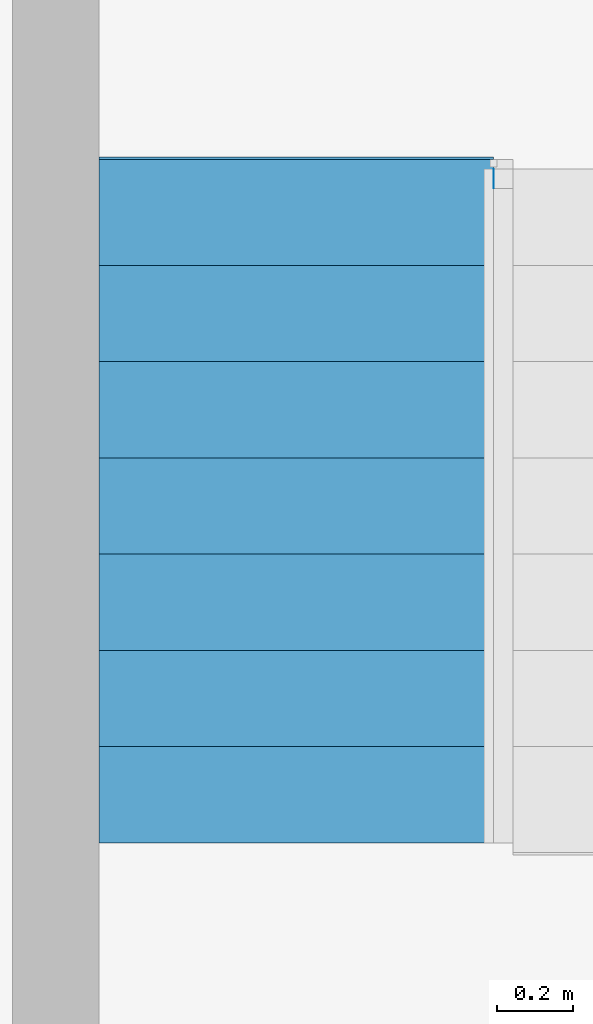
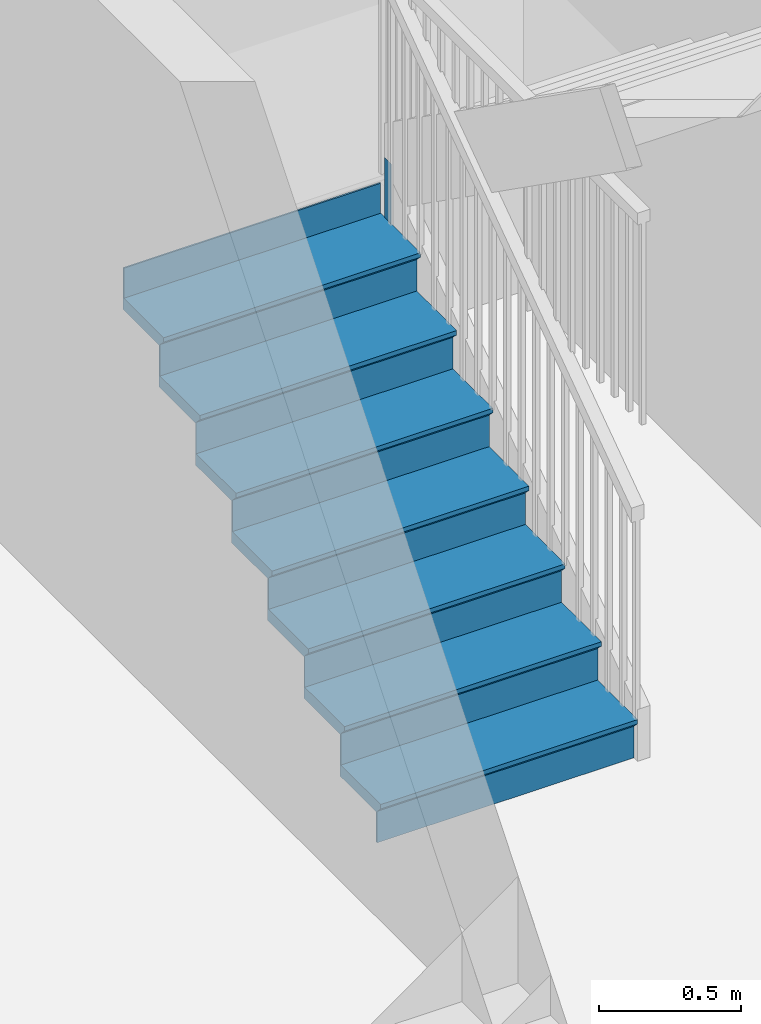
# One storey, part 4 of 6: 1 member, 1 stair flight, 1 element without a shape of its own.
"""IFC2X3 building model written with IfcOpenShell, lengths in feet."""

from ifc_helpers import new_model, entity, si_unit, converted_unit, derived_unit, direction, frame, origin, place, context, subcontext, project, spatial, face_set, faceted_brep, surface_model, material, type_object, element, aggregate, save


model = new_model("IFC2X3")

# Units and contexts
model_context = context("Model", 3, precision=0.0001, world=origin(), true_north=direction((6.123031769111886e-17, 1.0)))
body_context = subcontext(model_context, "Body", "Model", "MODEL_VIEW")
ifc_project = project(units=[converted_unit("LENGTHUNIT", "FOOT", entity("IfcLengthMeasure", 0.3048), si_unit("LENGTHUNIT", "METRE"), dimensions=[1, 0, 0, 0, 0, 0, 0]), converted_unit("AREAUNIT", "SQUARE FOOT", entity("IfcAreaMeasure", 0.09290304), si_unit("AREAUNIT", "SQUARE_METRE"), dimensions=[2, 0, 0, 0, 0, 0, 0]), converted_unit("VOLUMEUNIT", "CUBIC FOOT", entity("IfcVolumeMeasure", 0.028316846592000004), si_unit("VOLUMEUNIT", "CUBIC_METRE"), dimensions=[3, 0, 0, 0, 0, 0, 0]), converted_unit("PLANEANGLEUNIT", "DEGREE", entity("IfcPlaneAngleMeasure", 0.017453292519943278), si_unit("PLANEANGLEUNIT", "RADIAN"), dimensions=[0, 0, 0, 0, 0, 0, 0]), si_unit("MASSUNIT", "GRAM", prefix="KILO"), derived_unit("MASSDENSITYUNIT", [(si_unit("MASSUNIT", "GRAM", prefix="KILO"), 1), (si_unit("LENGTHUNIT", "METRE"), -3)]), derived_unit("IONCONCENTRATIONUNIT", [(si_unit("MASSUNIT", "GRAM", prefix="KILO"), 1), (si_unit("LENGTHUNIT", "METRE"), -3)]), derived_unit("MOMENTOFINERTIAUNIT", [(si_unit("LENGTHUNIT", "METRE"), 4)]), si_unit("TIMEUNIT", "SECOND"), si_unit("FREQUENCYUNIT", "HERTZ"), si_unit("THERMODYNAMICTEMPERATUREUNIT", "DEGREE_CELSIUS"), derived_unit("THERMALTRANSMITTANCEUNIT", [(si_unit("MASSUNIT", "GRAM", prefix="KILO"), 1), (si_unit("THERMODYNAMICTEMPERATUREUNIT", "KELVIN"), -1), (si_unit("TIMEUNIT", "SECOND"), -3)]), derived_unit("THERMALCONDUCTANCEUNIT", [(si_unit("MASSUNIT", "GRAM", prefix="KILO"), 1), (si_unit("THERMODYNAMICTEMPERATUREUNIT", "KELVIN"), -1), (si_unit("TIMEUNIT", "SECOND"), -3), (si_unit("LENGTHUNIT", "METRE"), 1)]), derived_unit("VOLUMETRICFLOWRATEUNIT", [(si_unit("LENGTHUNIT", "METRE"), 3), (si_unit("TIMEUNIT", "SECOND"), -1)]), derived_unit("MASSFLOWRATEUNIT", [(si_unit("MASSUNIT", "GRAM", prefix="KILO"), 1), (si_unit("TIMEUNIT", "SECOND"), -1)]), derived_unit("ROTATIONALFREQUENCYUNIT", [(si_unit("TIMEUNIT", "SECOND"), -1)]), si_unit("ELECTRICCURRENTUNIT", "AMPERE"), si_unit("ELECTRICVOLTAGEUNIT", "VOLT"), si_unit("POWERUNIT", "WATT"), converted_unit("FORCEUNIT", "KIP", entity("IfcForceMeasure", 2.088543423315013e-05), si_unit("FORCEUNIT", "NEWTON"), dimensions=[1, 1, -2, 0, 0, 0, 0]), si_unit("ILLUMINANCEUNIT", "LUX"), si_unit("LUMINOUSFLUXUNIT", "LUMEN"), si_unit("LUMINOUSINTENSITYUNIT", "CANDELA"), si_unit("ENERGYUNIT", "JOULE"), derived_unit("USERDEFINED", [(si_unit("MASSUNIT", "GRAM", prefix="KILO"), -1), (si_unit("LENGTHUNIT", "METRE"), -2), (si_unit("TIMEUNIT", "SECOND"), 3), (si_unit("LUMINOUSFLUXUNIT", "LUMEN"), 1)]), derived_unit("USERDEFINED", [(si_unit("MASSUNIT", "GRAM", prefix="KILO"), 1), (si_unit("TIMEUNIT", "SECOND"), -3), (si_unit("LENGTHUNIT", "METRE"), 3), (si_unit("ELECTRICCURRENTUNIT", "AMPERE"), -2)]), derived_unit("SOUNDPOWERUNIT", [(si_unit("MASSUNIT", "GRAM", prefix="KILO"), 1), (si_unit("TIMEUNIT", "SECOND"), -3), (si_unit("LENGTHUNIT", "METRE"), 2)]), derived_unit("SOUNDPRESSUREUNIT", [(si_unit("MASSUNIT", "GRAM", prefix="KILO"), 1), (si_unit("LENGTHUNIT", "METRE"), -1), (si_unit("TIMEUNIT", "SECOND"), -2)]), derived_unit("LINEARVELOCITYUNIT", [(si_unit("LENGTHUNIT", "METRE"), 1), (si_unit("TIMEUNIT", "SECOND"), -1)]), si_unit("PRESSUREUNIT", "PASCAL"), derived_unit("USERDEFINED", [(si_unit("MASSUNIT", "GRAM", prefix="KILO"), 1), (si_unit("LENGTHUNIT", "METRE"), -2), (si_unit("TIMEUNIT", "SECOND"), -2)]), derived_unit("LINEARFORCEUNIT", [(si_unit("MASSUNIT", "GRAM", prefix="KILO"), 1), (si_unit("TIMEUNIT", "SECOND"), -2)]), derived_unit("PLANARFORCEUNIT", [(si_unit("MASSUNIT", "GRAM", prefix="KILO"), 1), (si_unit("LENGTHUNIT", "METRE"), -1), (si_unit("TIMEUNIT", "SECOND"), -2)]), derived_unit("SPECIFICHEATCAPACITYUNIT", [(si_unit("THERMODYNAMICTEMPERATUREUNIT", "KELVIN"), -1), (si_unit("LENGTHUNIT", "METRE"), 2), (si_unit("TIMEUNIT", "SECOND"), -2)]), derived_unit("HEATFLUXDENSITYUNIT", [(si_unit("MASSUNIT", "GRAM", prefix="KILO"), 1), (si_unit("TIMEUNIT", "SECOND"), -3)]), derived_unit("HEATINGVALUEUNIT", [(si_unit("LENGTHUNIT", "METRE"), 2), (si_unit("TIMEUNIT", "SECOND"), -2)]), derived_unit("VAPORPERMEABILITYUNIT", [(si_unit("LENGTHUNIT", "METRE"), -1), (si_unit("TIMEUNIT", "SECOND"), 1)]), derived_unit("DYNAMICVISCOSITYUNIT", [(si_unit("MASSUNIT", "GRAM", prefix="KILO"), 1), (si_unit("TIMEUNIT", "SECOND"), -1), (si_unit("LENGTHUNIT", "METRE"), -1)]), derived_unit("THERMALEXPANSIONCOEFFICIENTUNIT", [(si_unit("THERMODYNAMICTEMPERATUREUNIT", "KELVIN"), -1)]), derived_unit("MODULUSOFELASTICITYUNIT", [(si_unit("MASSUNIT", "GRAM", prefix="KILO"), 1), (si_unit("LENGTHUNIT", "METRE"), -1), (si_unit("TIMEUNIT", "SECOND"), -2)]), derived_unit("ISOTHERMALMOISTURECAPACITYUNIT", [(si_unit("LENGTHUNIT", "METRE"), 3), (si_unit("MASSUNIT", "GRAM", prefix="KILO"), -1)]), derived_unit("MOISTUREDIFFUSIVITYUNIT", [(si_unit("TIMEUNIT", "SECOND"), -1), (si_unit("LENGTHUNIT", "METRE"), 2)]), derived_unit("MASSPERLENGTHUNIT", [(si_unit("MASSUNIT", "GRAM", prefix="KILO"), 1), (si_unit("LENGTHUNIT", "METRE"), -1)]), derived_unit("THERMALRESISTANCEUNIT", [(si_unit("MASSUNIT", "GRAM", prefix="KILO"), -1), (si_unit("TIMEUNIT", "SECOND"), 3), (si_unit("THERMODYNAMICTEMPERATUREUNIT", "KELVIN"), 1)]), derived_unit("ACCELERATIONUNIT", [(si_unit("LENGTHUNIT", "METRE"), 1), (si_unit("TIMEUNIT", "SECOND"), -2)]), derived_unit("ANGULARVELOCITYUNIT", [(si_unit("TIMEUNIT", "SECOND"), -1), (si_unit("PLANEANGLEUNIT", "RADIAN"), 1)]), derived_unit("LINEARSTIFFNESSUNIT", [(si_unit("MASSUNIT", "GRAM", prefix="KILO"), 1), (si_unit("TIMEUNIT", "SECOND"), -2)]), derived_unit("WARPINGCONSTANTUNIT", [(si_unit("LENGTHUNIT", "METRE"), 6)]), derived_unit("LINEARMOMENTUNIT", [(si_unit("MASSUNIT", "GRAM", prefix="KILO"), 1), (si_unit("LENGTHUNIT", "METRE"), 1), (si_unit("TIMEUNIT", "SECOND"), -2)]), derived_unit("TORQUEUNIT", [(si_unit("MASSUNIT", "GRAM", prefix="KILO"), 1), (si_unit("LENGTHUNIT", "METRE"), 2), (si_unit("TIMEUNIT", "SECOND"), -2)])], contexts=[model_context])

# Site, building, storey
site_placement = place(None, origin())
site = spatial("IfcSite", under=ifc_project, at=site_placement, CompositionType="ELEMENT")
building_placement = place(site_placement, origin())
building = spatial("IfcBuilding", under=site, at=building_placement, CompositionType="ELEMENT")
storey_placement = place(building_placement, origin())
storey = spatial("IfcBuildingStorey", under=building, at=storey_placement, Name="Level 1", CompositionType="ELEMENT", Elevation=0.0)

# Stair, member, stair flight
type_product = type_object("IfcTypeProduct")
stair_placement = place(storey_placement, origin())
stair = element("IfcStair", 1, at=stair_placement, inside=storey, type_object=type_product, Name="Assembled Stair:Stair", ShapeType="HALF_TURN_STAIR")
ifc_material = material()
member_type = type_object("IfcMemberType", PredefinedType="STRINGER")
member_placement = place(stair_placement, frame((-3.1182464185844676, 12.833913631404993, 3.958333333334167)))
member = element("IfcMember", 2, at=member_placement, type_object=member_type, material=ifc_material, Name="Assembled Stair:Stair:385185 Stringer 3", context=body_context, shape_type="SurfaceModel", body=[
    surface_model("IfcFaceBasedSurfaceModel", [(0.0, 0.0, 1.0), (0.0, 0.0, 0.0), (0.0, 0.1666666666666643, 0.0), (0.0, 0.1666666666666643, 1.0)], [face_set([[[0, 1, 2, 3]], [[0, 1, 2, 3]]])]),
])
stair_flight_type = type_object("IfcStairFlightType", PredefinedType="STRAIGHT")
stair_flight_placement = place(stair_placement, frame((-6.534913085251143, 7.167246964738325, 0.0)))
stair_flight = element("IfcStairFlight", 3, at=stair_flight_placement, type_object=stair_flight_type, material=ifc_material, Name="Assembled Stair:Stair:385185 Run 1", NumberOfRiser=8, NumberOfTreads=7, RiserHeight=0.588541666666771, TreadLength=0.8333333333333334, context=body_context, shape_type="Brep", body=[
    faceted_brep([(3.416666666666666, 0.0, 0.526041666666771), (3.416666666666666, 0.0, 0.588541666666771), (0.0, 0.0, 0.588541666666771), (0.0, 0.0, 0.526041666666771), (3.416666666666666, 0.08333333333333215, 0.4427083333334374), (0.0, 0.08333333333333925, 0.4427083333334375), (3.416666666666668, 0.9166666666666679, 0.588541666666771), (0.0, 0.9166666666666714, 0.588541666666771), (0.0, 0.08333333333333925, 0.42187500000010436), (0.0, 0.9166666666666714, 0.42187500000010436), (3.4166666666666674, 0.9166666666666679, 0.42187500000010436), (3.416666666666666, 0.08333333333333215, 0.42187500000010436)], [[[0, 1, 2, 3]], [[4, 0, 3, 5]], [[2, 1, 6, 7]], [[8, 9, 10, 11]], [[2, 7, 9, 8, 5, 3]], [[8, 11, 4, 5]], [[6, 1, 0, 4, 11, 10]], [[7, 6, 10, 9]]]),
    faceted_brep([(3.416666666666666, 0.08333333333333215, 0.42187500000010436), (3.416666666666666, 0.08333333333333215, 0.0), (3.416666666666666, 0.10416666666666519, 0.0), (3.416666666666666, 0.10416666666666519, 0.42187500000010436), (0.0, 0.08333333333333925, 0.42187500000010436), (0.0, 0.10416666666667229, 0.42187500000010436), (0.0, 0.10416666666667229, 0.0), (0.0, 0.08333333333333925, 0.0)], [[[0, 1, 2, 3]], [[4, 5, 6, 7]], [[1, 0, 4, 7]], [[2, 1, 7, 6]], [[3, 2, 6, 5]], [[0, 3, 5, 4]]]),
    faceted_brep([(3.416666666666668, 0.9166666666666679, 1.0104166666668752), (3.416666666666668, 0.9166666666666679, 0.42187500000010436), (3.416666666666668, 0.9375000000000018, 0.42187500000010425), (3.416666666666668, 0.9375000000000018, 1.0104166666668752), (0.0, 0.9166666666666714, 1.0104166666668752), (0.0, 0.9375000000000053, 1.0104166666668752), (0.0, 0.9375000000000053, 0.42187500000010436), (0.0, 0.9166666666666714, 0.42187500000010436)], [[[0, 1, 2, 3]], [[4, 5, 6, 7]], [[1, 0, 4, 7]], [[2, 1, 7, 6]], [[3, 2, 6, 5]], [[0, 3, 5, 4]]]),
    faceted_brep([(0.0, 0.8333333333333375, 1.177083333333542), (3.4166666666666674, 0.8333333333333339, 1.177083333333542), (3.4166666666666687, 1.75, 1.177083333333542), (0.0, 1.750000000000007, 1.177083333333542), (0.0, 0.9166666666666714, 1.0104166666668752), (0.0, 1.750000000000007, 1.0104166666668752), (3.4166666666666687, 1.75, 1.0104166666668752), (3.416666666666668, 0.9166666666666679, 1.0104166666668752), (0.0, 0.9166666666666714, 1.0312500000002083), (0.0, 0.8333333333333375, 1.114583333333542), (3.4166666666666674, 0.9166666666666679, 1.0312500000002085), (3.4166666666666674, 0.8333333333333339, 1.114583333333542)], [[[0, 1, 2, 3]], [[4, 5, 6, 7]], [[0, 3, 5, 4, 8, 9]], [[4, 7, 10, 8]], [[2, 1, 11, 10, 7, 6]], [[3, 2, 6, 5]], [[11, 1, 0, 9]], [[10, 11, 9, 8]]]),
    faceted_brep([(3.4166666666666696, 1.75, 1.5989583333336463), (3.4166666666666696, 1.75, 1.0104166666668755), (3.4166666666666696, 1.770833333333334, 1.0104166666668752), (3.4166666666666696, 1.770833333333334, 1.5989583333336463), (0.0, 1.7500000000000036, 1.5989583333336463), (0.0, 1.7708333333333375, 1.5989583333336463), (0.0, 1.7708333333333375, 1.0104166666668755), (0.0, 1.7500000000000036, 1.0104166666668755)], [[[0, 1, 2, 3]], [[4, 5, 6, 7]], [[1, 0, 4, 7]], [[2, 1, 7, 6]], [[3, 2, 6, 5]], [[0, 3, 5, 4]]]),
    faceted_brep([(0.0, 1.6666666666666696, 1.765625000000313), (3.416666666666669, 1.666666666666666, 1.765625000000313), (3.4166666666666705, 2.583333333333332, 1.765625000000313), (0.0, 2.5833333333333393, 1.765625000000313), (0.0, 1.7500000000000036, 1.5989583333336463), (0.0, 2.5833333333333393, 1.5989583333336463), (3.4166666666666705, 2.583333333333332, 1.5989583333336463), (3.4166666666666696, 1.75, 1.5989583333336463), (0.0, 1.7500000000000036, 1.6197916666669794), (0.0, 1.6666666666666696, 1.703125000000313), (3.416666666666669, 1.75, 1.6197916666669796), (3.416666666666669, 1.666666666666666, 1.703125000000313)], [[[0, 1, 2, 3]], [[4, 5, 6, 7]], [[0, 3, 5, 4, 8, 9]], [[4, 7, 10, 8]], [[2, 1, 11, 10, 7, 6]], [[3, 2, 6, 5]], [[11, 1, 0, 9]], [[10, 11, 9, 8]]]),
    faceted_brep([(3.4166666666666705, 2.583333333333334, 2.1875000000004174), (3.4166666666666705, 2.583333333333334, 1.5989583333336468), (3.4166666666666705, 2.604166666666668, 1.5989583333336466), (3.4166666666666705, 2.604166666666668, 2.1875000000004174), (0.0, 2.5833333333333375, 2.1875000000004174), (0.0, 2.6041666666666714, 2.1875000000004174), (0.0, 2.6041666666666714, 1.5989583333336468), (0.0, 2.5833333333333375, 1.5989583333336468)], [[[0, 1, 2, 3]], [[4, 5, 6, 7]], [[1, 0, 4, 7]], [[2, 1, 7, 6]], [[3, 2, 6, 5]], [[0, 3, 5, 4]]]),
    faceted_brep([(0.0, 2.5000000000000036, 2.3541666666670844), (3.41666666666667, 2.5, 2.3541666666670844), (3.4166666666666714, 3.416666666666666, 2.3541666666670844), (0.0, 3.416666666666673, 2.3541666666670844), (0.0, 2.5833333333333375, 2.1875000000004174), (0.0, 3.416666666666673, 2.1875000000004174), (3.4166666666666714, 3.416666666666666, 2.1875000000004174), (3.4166666666666705, 2.583333333333334, 2.1875000000004174), (0.0, 2.5833333333333375, 2.2083333333337505), (0.0, 2.5000000000000036, 2.2916666666670844), (3.41666666666667, 2.583333333333334, 2.208333333333751), (3.41666666666667, 2.5, 2.2916666666670844)], [[[0, 1, 2, 3]], [[4, 5, 6, 7]], [[0, 3, 5, 4, 8, 9]], [[4, 7, 10, 8]], [[2, 1, 11, 10, 7, 6]], [[3, 2, 6, 5]], [[11, 1, 0, 9]], [[10, 11, 9, 8]]]),
    faceted_brep([(3.4166666666666723, 3.416666666666666, 2.7760416666671883), (3.4166666666666723, 3.416666666666666, 2.1875000000004174), (3.4166666666666723, 3.4375, 2.1875000000004174), (3.4166666666666723, 3.4375, 2.7760416666671883), (0.0, 3.4166666666666696, 2.7760416666671883), (0.0, 3.4375000000000036, 2.7760416666671883), (0.0, 3.4375000000000036, 2.1875000000004174), (0.0, 3.4166666666666696, 2.1875000000004174)], [[[0, 1, 2, 3]], [[4, 5, 6, 7]], [[1, 0, 4, 7]], [[2, 1, 7, 6]], [[3, 2, 6, 5]], [[0, 3, 5, 4]]]),
    faceted_brep([(0.0, 3.3333333333333357, 2.9427083333338553), (3.416666666666672, 3.333333333333332, 2.9427083333338553), (3.416666666666673, 4.249999999999998, 2.9427083333338553), (0.0, 4.250000000000005, 2.9427083333338553), (0.0, 3.4166666666666696, 2.7760416666671883), (0.0, 4.250000000000005, 2.7760416666671883), (3.416666666666673, 4.249999999999998, 2.7760416666671883), (3.4166666666666723, 3.416666666666666, 2.7760416666671883), (0.0, 3.4166666666666696, 2.7968750000005214), (0.0, 3.3333333333333357, 2.8802083333338553), (3.416666666666672, 3.416666666666666, 2.796875000000522), (3.416666666666672, 3.333333333333332, 2.8802083333338553)], [[[0, 1, 2, 3]], [[4, 5, 6, 7]], [[0, 3, 5, 4, 8, 9]], [[4, 7, 10, 8]], [[2, 1, 11, 10, 7, 6]], [[3, 2, 6, 5]], [[11, 1, 0, 9]], [[10, 11, 9, 8]]]),
    faceted_brep([(3.416666666666673, 4.250000000000002, 3.36458333333396), (3.416666666666673, 4.250000000000002, 2.776041666667189), (3.416666666666673, 4.270833333333336, 2.7760416666671888), (3.416666666666673, 4.270833333333336, 3.36458333333396), (0.0, 4.250000000000005, 3.36458333333396), (0.0, 4.270833333333339, 3.36458333333396), (0.0, 4.270833333333339, 2.776041666667189), (0.0, 4.250000000000005, 2.776041666667189)], [[[0, 1, 2, 3]], [[4, 5, 6, 7]], [[1, 0, 4, 7]], [[2, 1, 7, 6]], [[3, 2, 6, 5]], [[0, 3, 5, 4]]]),
    faceted_brep([(0.0, 4.166666666666671, 3.5312500000006266), (3.4166666666666727, 4.166666666666668, 3.5312500000006266), (3.416666666666674, 5.083333333333334, 3.5312500000006266), (0.0, 5.083333333333341, 3.5312500000006266), (0.0, 4.250000000000005, 3.3645833333339596), (0.0, 5.083333333333341, 3.3645833333339596), (3.416666666666674, 5.083333333333334, 3.3645833333339596), (3.416666666666673, 4.250000000000002, 3.3645833333339596), (0.0, 4.250000000000005, 3.385416666667293), (0.0, 4.166666666666671, 3.4687500000006266), (3.4166666666666727, 4.250000000000002, 3.385416666667293), (3.4166666666666727, 4.166666666666668, 3.4687500000006266)], [[[0, 1, 2, 3]], [[4, 5, 6, 7]], [[0, 3, 5, 4, 8, 9]], [[4, 7, 10, 8]], [[2, 1, 11, 10, 7, 6]], [[3, 2, 6, 5]], [[11, 1, 0, 9]], [[10, 11, 9, 8]]]),
    faceted_brep([(3.416666666666676, 5.916666666666668, 4.541666666667502), (3.416666666666676, 5.916666666666668, 3.9531250000007305), (3.416666666666676, 5.937500000000002, 3.95312500000073), (3.416666666666676, 5.937500000000002, 4.541666666667501), (0.0, 5.916666666666671, 4.541666666667501), (0.0, 5.937500000000005, 4.541666666667501), (0.0, 5.937500000000005, 3.9531250000007305), (0.0, 5.916666666666671, 3.9531250000007305)], [[[0, 1, 2, 3]], [[4, 5, 6, 7]], [[1, 0, 4, 7]], [[2, 1, 7, 6]], [[3, 2, 6, 5]], [[0, 3, 5, 4]]]),
    faceted_brep([(3.416666666666674, 5.083333333333334, 3.95312500000073), (3.416666666666674, 5.083333333333334, 3.364583333333959), (3.416666666666674, 5.104166666666668, 3.3645833333339596), (3.416666666666674, 5.104166666666668, 3.9531250000007305), (0.0, 5.083333333333341, 3.9531250000007305), (0.0, 5.104166666666675, 3.9531250000007305), (0.0, 5.104166666666675, 3.364583333333959), (0.0, 5.083333333333341, 3.364583333333959)], [[[0, 1, 2, 3]], [[4, 5, 6, 7]], [[1, 0, 4, 7]], [[2, 1, 7, 6]], [[3, 2, 6, 5]], [[0, 3, 5, 4]]]),
    faceted_brep([(0.0, 5.916666666666671, 4.119791666667397), (0.0, 5.8333333333333375, 4.119791666667397), (0.0, 5.0, 4.119791666667397), (3.416666666666674, 5.0, 4.119791666667397), (3.416666666666676, 5.916666666666668, 4.119791666667397), (0.0, 5.833333333333339, 3.9531250000007305), (0.0, 5.916666666666671, 3.9531250000007305), (3.4166666666666754, 5.916666666666668, 3.9531250000007305), (3.416666666666674, 5.083333333333334, 3.9531250000007305), (0.0, 5.083333333333341, 3.9531250000007305), (0.0, 5.083333333333341, 3.9739583333340636), (0.0, 5.0, 4.057291666667397), (3.416666666666674, 5.083333333333334, 3.973958333334064), (3.416666666666674, 5.0, 4.057291666667397)], [[[0, 1, 2, 3, 4]], [[5, 6, 7, 8, 9]], [[1, 0, 6, 5]], [[2, 1, 5, 9, 10, 11]], [[9, 8, 12, 10]], [[4, 3, 13, 12, 8, 7]], [[0, 4, 7, 6]], [[13, 3, 2, 11]], [[12, 13, 11, 10]]]),
])
aggregate(stair, [stair_flight, member])

save(model, "model.ifc")
